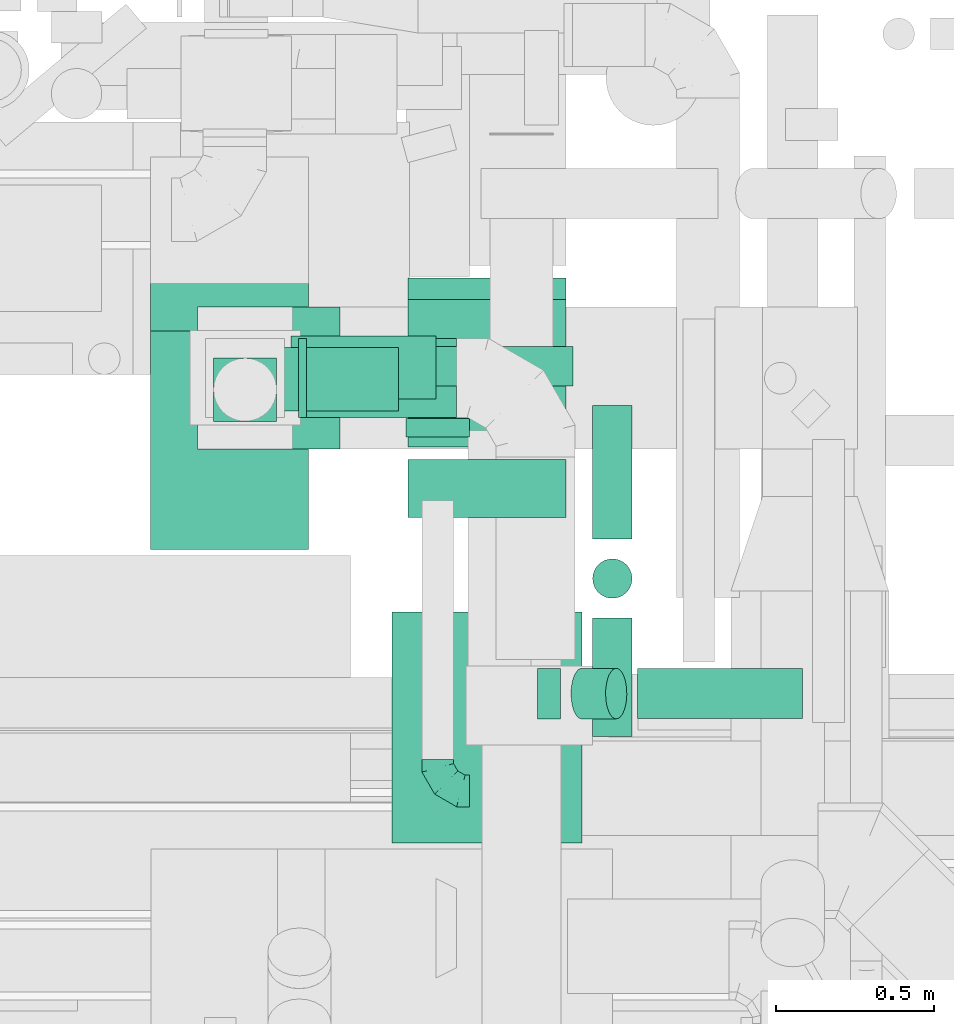
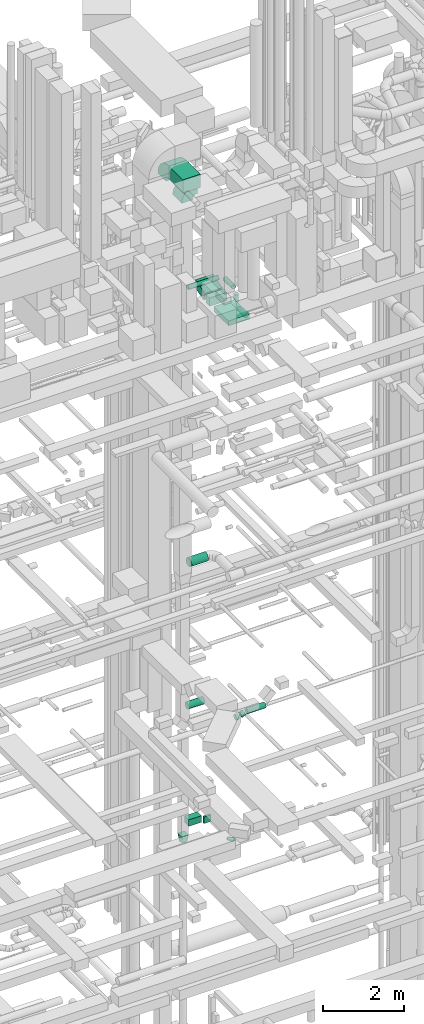
# One storey, part 187 of 337: 15 flow segments, 5 flow fittings.
"""IFC2X3 building model written with IfcOpenShell, lengths in millimetres."""

from ifc_helpers import new_model, entity, si_unit, converted_unit, derived_unit, direction, frame, frame_2d, origin, origin_2d_with_axis, place, context, subcontext, project, spatial, polyline, circle_curve, parameter, trimmed, segment, composite_curve, rectangle, circle, outline, extrude, faceted_brep, source, transform, mapped, material, type_object, type_shapes, element, save


model = new_model("IFC2X3")

# Units and contexts
model_context = context("Model", 3, precision=0.01, world=origin(), true_north=direction((6.12303176911189e-17, 1.0)))
body_context = subcontext(model_context, "Body", "Model", "MODEL_VIEW")
ifc_project = project(units=[si_unit("LENGTHUNIT", "METRE", prefix="MILLI"), si_unit("AREAUNIT", "SQUARE_METRE"), si_unit("VOLUMEUNIT", "CUBIC_METRE"), converted_unit("PLANEANGLEUNIT", "DEGREE", entity("IfcRatioMeasure", 0.0174532925199433), si_unit("PLANEANGLEUNIT", "RADIAN"), dimensions=[0, 0, 0, 0, 0, 0, 0]), si_unit("MASSUNIT", "GRAM", prefix="KILO"), derived_unit("MASSDENSITYUNIT", [(si_unit("MASSUNIT", "GRAM", prefix="KILO"), 1), (si_unit("LENGTHUNIT", "METRE"), -3)]), derived_unit("MOMENTOFINERTIAUNIT", [(si_unit("LENGTHUNIT", "METRE"), 4)]), si_unit("TIMEUNIT", "SECOND"), si_unit("FREQUENCYUNIT", "HERTZ"), si_unit("THERMODYNAMICTEMPERATUREUNIT", "DEGREE_CELSIUS"), derived_unit("THERMALTRANSMITTANCEUNIT", [(si_unit("MASSUNIT", "GRAM", prefix="KILO"), 1), (si_unit("THERMODYNAMICTEMPERATUREUNIT", "KELVIN"), -1), (si_unit("TIMEUNIT", "SECOND"), -3)]), derived_unit("VOLUMETRICFLOWRATEUNIT", [(si_unit("LENGTHUNIT", "METRE"), 3), (si_unit("TIMEUNIT", "SECOND"), -1)]), derived_unit("MASSFLOWRATEUNIT", [(si_unit("MASSUNIT", "GRAM", prefix="KILO"), 1), (si_unit("TIMEUNIT", "SECOND"), -1)]), derived_unit("ROTATIONALFREQUENCYUNIT", [(si_unit("TIMEUNIT", "SECOND"), -1)]), si_unit("ELECTRICCURRENTUNIT", "AMPERE"), si_unit("ELECTRICVOLTAGEUNIT", "VOLT"), si_unit("POWERUNIT", "WATT"), si_unit("FORCEUNIT", "NEWTON", prefix="KILO"), si_unit("ILLUMINANCEUNIT", "LUX"), si_unit("LUMINOUSFLUXUNIT", "LUMEN"), si_unit("LUMINOUSINTENSITYUNIT", "CANDELA"), derived_unit("USERDEFINED", [(si_unit("MASSUNIT", "GRAM", prefix="KILO"), -1), (si_unit("LENGTHUNIT", "METRE"), -2), (si_unit("TIMEUNIT", "SECOND"), 3), (si_unit("LUMINOUSFLUXUNIT", "LUMEN"), 1)]), derived_unit("LINEARVELOCITYUNIT", [(si_unit("LENGTHUNIT", "METRE"), 1), (si_unit("TIMEUNIT", "SECOND"), -1)]), si_unit("PRESSUREUNIT", "PASCAL"), derived_unit("USERDEFINED", [(si_unit("LENGTHUNIT", "METRE"), -2), (si_unit("MASSUNIT", "GRAM", prefix="KILO"), 1), (si_unit("TIMEUNIT", "SECOND"), -2)]), derived_unit("LINEARFORCEUNIT", [(si_unit("MASSUNIT", "GRAM", prefix="KILO"), 1), (si_unit("LENGTHUNIT", "METRE"), 1), (si_unit("TIMEUNIT", "SECOND"), -2), (si_unit("LENGTHUNIT", "METRE"), -1)]), derived_unit("PLANARFORCEUNIT", [(si_unit("MASSUNIT", "GRAM", prefix="KILO"), 1), (si_unit("LENGTHUNIT", "METRE"), 1), (si_unit("TIMEUNIT", "SECOND"), -2), (si_unit("LENGTHUNIT", "METRE"), -2)])], contexts=[model_context])

# Site, building, storey
site_placement = place(None, origin())
site = spatial("IfcSite", under=ifc_project, at=site_placement, CompositionType="ELEMENT")
building_placement = place(site_placement, origin())
building = spatial("IfcBuilding", under=site, at=building_placement, CompositionType="ELEMENT")
storey_placement = place(building_placement, origin())
storey = spatial("IfcBuildingStorey", under=building, at=storey_placement, CompositionType="ELEMENT", Elevation=0.0)

# Flow segments
duct_segment_type_1 = type_object("IfcDuctSegmentType", PredefinedType="NOTDEFINED")
flow_segment_1_placement = place(storey_placement, frame((52720.03, 11170.4, 11370.0)))
element("IfcFlowSegment", 1, at=flow_segment_1_placement, inside=storey, type_object=duct_segment_type_1, context=body_context, shape_type="SweptSolid", body=[
    extrude(rectangle(XDim=364.85556818635, YDim=200.0, at=origin_2d_with_axis()), frame((182.43, 100.0, 0.0), z_axis=(0.0, 0.0, 1.0), x_axis=(-1.0, 0.0, 0.0)), (0.0, 0.0, 1.0), 199.999999999998),
])
flow_segment_2_placement = place(storey_placement, frame((53109.89, 11086.79, 11370.0)))
element("IfcFlowSegment", 2, at=flow_segment_2_placement, inside=storey, type_object=duct_segment_type_1, context=body_context, shape_type="SweptSolid", body=[
    extrude(rectangle(XDim=58.6039573661216, YDim=199.999999999998, at=origin_2d_with_axis()), frame((100.0, 29.3, 0.0), z_axis=(0.0, 0.0, 1.0), x_axis=(0.0, -1.0, 0.0)), (0.0, 0.0, 1.0), 199.999999999998),
])
flow_segment_3_placement = place(storey_placement, frame((53065.82, 9802.55, 27150.0)))
element("IfcFlowSegment", 3, at=flow_segment_3_placement, inside=storey, type_object=duct_segment_type_1, context=body_context, shape_type="SweptSolid", body=[
    extrude(rectangle(XDim=730.779196872407, YDim=600.000000000002, at=origin_2d_with_axis()), frame((300.0, 365.39, 0.0), z_axis=(0.0, 0.0, 1.0), x_axis=(0.0, 1.0, 0.0)), (0.0, 0.0, 1.0), 150.000000000001),
])
flow_segment_4_placement = place(storey_placement, frame((53115.82, 10833.33, 27100.0)))
element("IfcFlowSegment", 4, at=flow_segment_4_placement, inside=storey, type_object=duct_segment_type_1, context=body_context, shape_type="SweptSolid", body=[
    extrude(rectangle(XDim=182.495508005278, YDim=499.999999999999, at=origin_2d_with_axis()), frame((250.0, 91.25, 0.0), z_axis=(0.0, 0.0, 1.0), x_axis=(0.0, 1.0, 0.0)), (0.0, 0.0, 1.0), 250.000000000004),
])
flow_segment_5_placement = place(storey_placement, frame((53115.82, 11056.0, 27114.61)))
element("IfcFlowSegment", 5, at=flow_segment_5_placement, inside=storey, type_object=duct_segment_type_1, context=body_context, shape_type="SweptSolid", body=[
    extrude(rectangle(XDim=250.000000000005, YDim=485.15363912892, at=frame_2d((0.0, 0.0), x_axis=(0.0, 1.0))), frame((0.0, 267.19, 185.39), z_axis=(1.0, 0.0, 0.0), x_axis=(0.0, 0.963480255930641, 0.267779380146841)), (0.0, 0.0, 1.0), 500.000000000008),
])
flow_segment_6_placement = place(storey_placement, frame((52300.35, 10731.5, 30855.02)))
element("IfcFlowSegment", 6, at=flow_segment_6_placement, inside=storey, type_object=duct_segment_type_1, context=body_context, shape_type="SweptSolid", body=[
    extrude(rectangle(XDim=691.839018428497, YDim=499.999999999999, at=origin_2d_with_axis()), frame((250.0, 345.92, 0.0), z_axis=(0.0, 0.0, 1.0), x_axis=(0.0, -1.0, 0.0)), (0.0, 0.0, 1.0), 400.000000000004),
])
duct_segment_type_2 = type_object("IfcDuctSegmentType", PredefinedType="NOTDEFINED")
flow_segment_7_placement = place(storey_placement, frame((52795.03, 11148.01, 19123.4)))
element("IfcFlowSegment", 7, at=flow_segment_7_placement, inside=storey, type_object=duct_segment_type_2, context=body_context, shape_type="SweptSolid", body=[
    extrude(circle(Radius=125.0, at=origin_2d_with_axis()), frame((0.0, 126.6, 126.6), z_axis=(1.0, 0.0, 0.0), x_axis=(0.0, 1.0, 0.0)), (0.0, 0.0, 1.0), 474.855752884465),
])
flow_segment_8_placement = place(storey_placement, frame((52745.03, 11206.18, 14818.4)))
element("IfcFlowSegment", 8, at=flow_segment_8_placement, inside=storey, type_object=duct_segment_type_2, context=body_context, shape_type="SweptSolid", body=[
    extrude(circle(Radius=100.0, at=origin_2d_with_axis()), frame((0.0, 101.6, 101.6), z_axis=(1.0, 0.0, 0.0), x_axis=(0.0, -1.0, 0.0)), (0.0, 0.0, 1.0), 459.993030000456),
])
flow_segment_9_placement = place(storey_placement, frame((53841.96, 10193.45, 14918.4)))
element("IfcFlowSegment", 9, at=flow_segment_9_placement, inside=storey, type_object=duct_segment_type_2, context=body_context, shape_type="SweptSolid", body=[
    extrude(circle(Radius=80.0, at=origin_2d_with_axis()), frame((0.0, 81.6, 81.6), z_axis=(1.0, 0.0, 0.0), x_axis=(0.0, 1.0, 0.0)), (0.0, 0.0, 1.0), 523.066679994511),
])
flow_segment_10_placement = place(storey_placement, frame((53525.03, 10193.45, 14838.4)))
element("IfcFlowSegment", 10, at=flow_segment_10_placement, inside=storey, type_object=duct_segment_type_2, context=body_context, shape_type="SweptSolid", body=[
    extrude(circle(Radius=80.0, at=origin_2d_with_axis()), frame((0.0, 81.6, 81.6), z_axis=(1.0, 0.0, 0.0), x_axis=(0.0, -1.0, 0.0)), (0.0, 0.0, 1.0), 73.3971976432189),
])
flow_segment_11_placement = place(storey_placement, frame((53630.37, 10193.45, 14860.52)))
element("IfcFlowSegment", 11, at=flow_segment_11_placement, inside=storey, type_object=duct_segment_type_2, context=body_context, shape_type="SweptSolid", body=[
    extrude(circle(Radius=80.0, at=origin_2d_with_axis()), frame((35.14, 81.6, 74.22), z_axis=(0.907841304111058, 0.0, 0.419313923629937), x_axis=(0.0, -1.0, 0.0)), (0.0, 0.0, 1.0), 120.456809252341),
])
flow_segment_12_placement = place(storey_placement, frame((52770.03, 11248.01, 27435.9)))
element("IfcFlowSegment", 12, at=flow_segment_12_placement, inside=storey, type_object=duct_segment_type_2, context=body_context, shape_type="SweptSolid", body=[
    extrude(circle(Radius=62.5, at=origin_2d_with_axis()), frame((0.0, 64.1, 64.1), z_axis=(1.0, 0.0, 0.0), x_axis=(0.0, 1.0, 0.0)), (0.0, 0.0, 1.0), 867.694165656165),
])
flow_segment_13_placement = place(storey_placement, frame((53698.63, 10139.17, 26945.9)))
element("IfcFlowSegment", 13, at=flow_segment_13_placement, inside=storey, type_object=duct_segment_type_2, context=body_context, shape_type="SweptSolid", body=[
    extrude(circle(Radius=62.5, at=origin_2d_with_axis()), frame((64.1, 0.0, 64.1), z_axis=(0.0, 1.0, 0.0), x_axis=(1.0, 0.0, 0.0)), (0.0, 0.0, 1.0), 374.999999999984),
])
flow_segment_14_placement = place(storey_placement, frame((53698.63, 10764.17, 27435.9)))
element("IfcFlowSegment", 14, at=flow_segment_14_placement, inside=storey, type_object=duct_segment_type_2, context=body_context, shape_type="SweptSolid", body=[
    extrude(circle(Radius=62.5, at=origin_2d_with_axis()), frame((64.1, 0.0, 64.1), z_axis=(0.0, 1.0, 0.0), x_axis=(-1.0, 0.0, 0.0)), (0.0, 0.0, 1.0), 422.937639147138),
])
flow_segment_15_placement = place(storey_placement, frame((53698.63, 10575.07, 27135.0)))
element("IfcFlowSegment", 15, at=flow_segment_15_placement, inside=storey, type_object=duct_segment_type_2, context=body_context, shape_type="SweptSolid", body=[
    extrude(circle(Radius=62.5, at=origin_2d_with_axis()), frame((64.1, 64.1, 0.0), z_axis=(0.0, 0.0, 1.0), x_axis=(-1.0, 0.0, 0.0)), (0.0, 0.0, 1.0), 240.000000000002),
])

# Flow fittings
ifc_material = material()
duct_fitting_type_1 = type_object("IfcDuctFittingType", PredefinedType="NOTDEFINED", material=ifc_material)
shared_shape_1 = source(origin(), body_context, "Body", "Brep", [
    faceted_brep([(-100.0, 0.0, -50.0), (-100.0, -12.94, -48.3), (-100.0, -25.0, -43.3), (-100.0, -35.36, -35.36), (-100.0, -43.3, -25.0), (-100.0, -48.3, -12.94), (-100.0, -50.0, 0.0), (-100.0, -48.3, 12.94), (-100.0, -43.3, 25.0), (-100.0, -35.36, 35.36), (-100.0, -25.0, 43.3), (-100.0, -12.94, 48.3), (-100.0, 0.0, 50.0), (-100.0, 12.94, 48.3), (-100.0, 25.0, 43.3), (-100.0, 35.36, 35.36), (-100.0, 43.3, 25.0), (-100.0, 48.3, 12.94), (-100.0, 50.0, 0.0), (-100.0, 48.3, -12.94), (-100.0, 43.3, -25.0), (-100.0, 35.36, -35.36), (-100.0, 25.0, -43.3), (-100.0, 12.94, -48.3), (-76.67, 12.94, 48.3), (-79.9, 25.0, 43.3), (-73.21, 0.0, 50.0), (-82.68, 35.36, 35.36), (-86.15, 48.3, 12.94), (-86.6, 50.0, 0.0), (-84.81, 43.3, 25.0), (-84.81, 43.3, -25.0), (-82.68, 35.36, -35.36), (-86.15, 48.3, -12.94), (-76.67, 12.94, -48.3), (-73.21, 0.0, -50.0), (-79.9, 25.0, -43.3), (-69.74, -12.94, -48.3), (-66.51, -25.0, -43.3), (-63.73, -35.36, -35.36), (-61.6, -43.3, -25.0), (-60.26, -48.3, -12.94), (-59.81, -50.0, 0.0), (-60.26, -48.3, 12.94), (-61.6, -43.3, 25.0), (-63.73, -35.36, 35.36), (-66.51, -25.0, 43.3), (-69.74, -12.94, 48.3), (-36.27, 36.27, 48.3), (-45.1, 45.1, 43.3), (-26.79, 26.79, 50.0), (-52.68, 52.68, 35.36), (-58.49, 58.49, 25.0), (-62.15, 62.15, 12.94), (-63.4, 63.4, 0.0), (-62.15, 62.15, -12.94), (-58.49, 58.49, -25.0), (-52.68, 52.68, -35.36), (-36.27, 36.27, -48.3), (-26.79, 26.79, -50.0), (-45.1, 45.1, -43.3), (-17.32, 17.32, -48.3), (-8.49, 8.49, -43.3), (-0.91, 0.91, -35.36), (4.9, -4.9, -25.0), (8.56, -8.56, -12.94), (9.81, -9.81, 0.0), (8.56, -8.56, 12.94), (4.9, -4.9, 25.0), (-0.91, 0.91, 35.36), (-8.49, 8.49, 43.3), (-17.32, 17.32, 48.3), (-12.94, 76.67, 48.3), (-25.0, 79.9, 43.3), (0.0, 73.21, 50.0), (-35.36, 82.68, 35.36), (-43.3, 84.81, 25.0), (-48.3, 86.15, 12.94), (-50.0, 86.6, 0.0), (-48.3, 86.15, -12.94), (-43.3, 84.81, -25.0), (-35.36, 82.68, -35.36), (-12.94, 76.67, -48.3), (0.0, 73.21, -50.0), (-25.0, 79.9, -43.3), (12.94, 69.74, -48.3), (25.0, 66.51, -43.3), (35.36, 63.73, -35.36), (43.3, 61.6, -25.0), (48.3, 60.26, -12.94), (50.0, 59.81, 0.0), (48.3, 60.26, 12.94), (43.3, 61.6, 25.0), (35.36, 63.73, 35.36), (25.0, 66.51, 43.3), (12.94, 69.74, 48.3), (-12.94, 100.0, -48.3), (-25.0, 100.0, -43.3), (-35.36, 100.0, -35.36), (-43.3, 100.0, -25.0), (-48.3, 100.0, -12.94), (-50.0, 100.0, 0.0), (-48.3, 100.0, 12.94), (-43.3, 100.0, 25.0), (-35.36, 100.0, 35.36), (-25.0, 100.0, 43.3), (-12.94, 100.0, 48.3), (0.0, 100.0, 50.0), (12.94, 100.0, 48.3), (25.0, 100.0, 43.3), (35.36, 100.0, 35.36), (43.3, 100.0, 25.0), (48.3, 100.0, 12.94), (50.0, 100.0, 0.0), (48.3, 100.0, -12.94), (43.3, 100.0, -25.0), (35.36, 100.0, -35.36), (25.0, 100.0, -43.3), (12.94, 100.0, -48.3), (0.0, 100.0, -50.0)], [[[0, 1, 2, 3, 4, 5, 6, 7, 8, 9, 10, 11, 12, 13, 14, 15, 16, 17, 18, 19, 20, 21, 22, 23]], [[24, 25, 14, 13]], [[26, 24, 13, 12]], [[14, 25, 27, 15]], [[28, 29, 18, 17]], [[30, 28, 17, 16]], [[15, 27, 30, 16]], [[20, 31, 32, 21]], [[33, 31, 20, 19]], [[18, 29, 33, 19]], [[34, 35, 0, 23]], [[36, 34, 23, 22]], [[32, 36, 22, 21]], [[2, 1, 37, 38]], [[3, 2, 38, 39]], [[0, 35, 37, 1]], [[5, 4, 40, 41]], [[6, 5, 41, 42]], [[3, 39, 40, 4]], [[6, 42, 43, 7]], [[7, 43, 44, 8]], [[8, 44, 45, 9]], [[10, 46, 47, 11]], [[11, 47, 26, 12]], [[10, 9, 45, 46]], [[48, 49, 25, 24]], [[50, 48, 24, 26]], [[27, 25, 49, 51]], [[52, 53, 28, 30]], [[51, 52, 30, 27]], [[29, 28, 53, 54]], [[55, 56, 31, 33]], [[54, 55, 33, 29]], [[57, 32, 31, 56]], [[58, 59, 35, 34]], [[60, 58, 34, 36]], [[57, 60, 36, 32]], [[37, 35, 59, 61]], [[38, 37, 61, 62]], [[39, 38, 62, 63]], [[41, 40, 64, 65]], [[42, 41, 65, 66]], [[63, 64, 40, 39]], [[43, 42, 66, 67]], [[44, 43, 67, 68]], [[68, 69, 45, 44]], [[46, 45, 69, 70]], [[47, 46, 70, 71]], [[26, 47, 71, 50]], [[72, 73, 49, 48]], [[74, 72, 48, 50]], [[51, 49, 73, 75]], [[76, 77, 53, 52]], [[75, 76, 52, 51]], [[54, 53, 77, 78]], [[79, 80, 56, 55]], [[78, 79, 55, 54]], [[81, 57, 56, 80]], [[82, 83, 59, 58]], [[84, 82, 58, 60]], [[81, 84, 60, 57]], [[61, 59, 83, 85]], [[62, 61, 85, 86]], [[63, 62, 86, 87]], [[65, 64, 88, 89]], [[66, 65, 89, 90]], [[87, 88, 64, 63]], [[67, 66, 90, 91]], [[68, 67, 91, 92]], [[92, 93, 69, 68]], [[70, 69, 93, 94]], [[71, 70, 94, 95]], [[50, 71, 95, 74]], [[96, 97, 98, 99, 100, 101, 102, 103, 104, 105, 106, 107, 108, 109, 110, 111, 112, 113, 114, 115, 116, 117, 118, 119]], [[72, 74, 107, 106]], [[73, 72, 106, 105]], [[75, 73, 105, 104]], [[77, 76, 103, 102]], [[78, 77, 102, 101]], [[75, 104, 103, 76]], [[78, 101, 100, 79]], [[79, 100, 99, 80]], [[80, 99, 98, 81]], [[96, 119, 83, 82]], [[97, 96, 82, 84]], [[84, 81, 98, 97]], [[83, 119, 118, 85]], [[85, 118, 117, 86]], [[86, 117, 116, 87]], [[88, 115, 114, 89]], [[89, 114, 113, 90]], [[87, 116, 115, 88]], [[91, 90, 113, 112]], [[92, 91, 112, 111]], [[93, 92, 111, 110]], [[95, 94, 109, 108]], [[74, 95, 108, 107]], [[110, 109, 94, 93]]]),
])
type_shapes(duct_fitting_type_1, [shared_shape_1])
flow_fitting_1_placement = place(storey_placement, frame((53209.89, 9966.79, 11520.0), z_axis=(0.0, 0.0, 1.0), x_axis=(0.0, -1.0, 0.0)))
element("IfcFlowFitting", 16, at=flow_fitting_1_placement, inside=storey, type_object=duct_fitting_type_1, material=ifc_material, context=body_context, shape_type="MappedRepresentation", body=[
    mapped(shared_shape_1, transform((0.0, 0.0, 0.0), scale=1.0)),
])
duct_fitting_type_2 = type_object("IfcDuctFittingType", PredefinedType="NOTDEFINED", material=ifc_material)
shared_shape_2 = source(origin(), body_context, "Body", "Brep", [
    faceted_brep([(20.0, 32.35, -120.74), (20.0, 62.5, -108.25), (20.0, 88.39, -88.39), (20.0, 108.25, -62.5), (20.0, 120.74, -32.35), (20.0, 125.0, 0.0), (20.0, 120.74, 32.35), (20.0, 108.25, 62.5), (20.0, 88.39, 88.39), (20.0, 62.5, 108.25), (20.0, 32.35, 120.74), (20.0, 0.0, 125.0), (20.0, -32.35, 120.74), (20.0, -62.5, 108.25), (20.0, -88.39, 88.39), (20.0, -108.25, 62.5), (20.0, -120.74, 32.35), (20.0, -125.0, 0.0), (20.0, -120.74, -32.35), (20.0, -108.25, -62.5), (20.0, -88.39, -88.39), (20.0, -62.5, -108.25), (20.0, -32.35, -120.74), (20.0, 0.0, -125.0), (0.0, 0.0, 125.0), (0.0, 32.35, 120.74), (-6.1, 32.35, 120.74), (-6.1, 0.0, 125.0), (0.0, 62.5, 108.25), (-6.1, 62.5, 108.25), (0.0, 88.39, 88.39), (-6.1, 88.39, 88.39), (0.0, 108.25, 62.5), (0.0, 120.74, 32.35), (-6.1, 120.74, 32.35), (-6.1, 108.25, 62.5), (0.0, 125.0, 0.0), (-6.1, 125.0, 0.0), (0.0, 120.74, -32.35), (-6.1, 120.74, -32.35), (0.0, 108.25, -62.5), (-6.1, 108.25, -62.5), (0.0, 88.39, -88.39), (-6.1, 88.39, -88.39), (0.0, 62.5, -108.25), (0.0, 32.35, -120.74), (-6.1, 32.35, -120.74), (-6.1, 62.5, -108.25), (0.0, 0.0, -125.0), (-6.1, 0.0, -125.0), (0.0, -32.35, -120.74), (-6.1, -32.35, -120.74), (0.0, -62.5, -108.25), (-6.1, -62.5, -108.25), (0.0, -88.39, -88.39), (-6.1, -88.39, -88.39), (0.0, -108.25, -62.5), (0.0, -120.74, -32.35), (-6.1, -120.74, -32.35), (-6.1, -108.25, -62.5), (0.0, -125.0, 0.0), (-6.1, -125.0, 0.0), (0.0, -120.74, 32.35), (-6.1, -120.74, 32.35), (0.0, -108.25, 62.5), (-6.1, -108.25, 62.5), (0.0, -88.39, 88.39), (-6.1, -88.39, 88.39), (0.0, -62.5, 108.25), (0.0, -32.35, 120.74), (-6.1, -32.35, 120.74), (-6.1, -62.5, 108.25)], [[[0, 1, 2, 3, 4, 5, 6, 7, 8, 9, 10, 11, 12, 13, 14, 15, 16, 17, 18, 19, 20, 21, 22, 23]], [[24, 11, 10, 25, 26, 27]], [[25, 10, 9, 28, 29, 26]], [[28, 9, 8, 30, 31, 29]], [[32, 7, 6, 33, 34, 35]], [[33, 6, 5, 36, 37, 34]], [[30, 8, 7, 32, 35, 31]], [[36, 5, 4, 38, 39, 37]], [[38, 4, 3, 40, 41, 39]], [[40, 3, 2, 42, 43, 41]], [[44, 1, 0, 45, 46, 47]], [[45, 0, 23, 48, 49, 46]], [[42, 2, 1, 44, 47, 43]], [[48, 23, 22, 50, 51, 49]], [[50, 22, 21, 52, 53, 51]], [[52, 21, 20, 54, 55, 53]], [[56, 19, 18, 57, 58, 59]], [[57, 18, 17, 60, 61, 58]], [[54, 20, 19, 56, 59, 55]], [[60, 17, 16, 62, 63, 61]], [[62, 16, 15, 64, 65, 63]], [[64, 15, 14, 66, 67, 65]], [[68, 13, 12, 69, 70, 71]], [[69, 12, 11, 24, 27, 70]], [[66, 14, 13, 68, 71, 67]], [[49, 51, 53, 55, 59, 58, 61, 63, 65, 67, 71, 70, 27, 26, 29, 31, 35, 34, 37, 39, 41, 43, 47, 46]]]),
])
type_shapes(duct_fitting_type_2, [shared_shape_2])
flow_fitting_2_placement = place(storey_placement, frame((52775.03, 11274.6, 19250.0), z_axis=(0.0, -1.0, 0.0), x_axis=(1.0, 0.0, 0.0)))
element("IfcFlowFitting", 17, at=flow_fitting_2_placement, inside=storey, type_object=duct_fitting_type_2, material=ifc_material, context=body_context, shape_type="MappedRepresentation", body=[
    mapped(shared_shape_2, transform((0.0, 0.0, 0.0), scale=1.0)),
])
duct_fitting_type_3 = type_object("IfcDuctFittingType", PredefinedType="NOTDEFINED", material=ifc_material)
shared_shape_3 = source(origin(), body_context, "Body", "Brep", [
    faceted_brep([(200.0, 30.9, 95.11), (200.0, 19.08, 96.98), (200.0, 9.54, 98.49), (200.0, 4.77, 99.24), (200.0, 0.0, 100.0), (200.0, -4.77, 99.24), (200.0, -9.54, 98.49), (200.0, -19.08, 96.98), (200.0, -30.9, 95.11), (200.0, -44.84, 88.0), (200.0, -58.78, 80.9), (200.0, -69.84, 69.84), (200.0, -80.9, 58.78), (200.0, -88.0, 44.84), (200.0, -95.11, 30.9), (200.0, -96.98, 19.08), (200.0, -98.49, 9.54), (200.0, -99.24, 4.77), (200.0, -100.0, 0.0), (200.0, -99.24, -4.77), (200.0, -98.49, -9.54), (200.0, -96.98, -19.08), (200.0, -95.11, -30.9), (200.0, -88.0, -44.84), (200.0, -80.9, -58.78), (200.0, -69.84, -69.84), (200.0, -58.78, -80.9), (200.0, -44.84, -88.0), (200.0, -30.9, -95.11), (200.0, -19.08, -96.98), (200.0, -9.54, -98.49), (200.0, -4.77, -99.24), (200.0, 0.0, -100.0), (200.0, 4.77, -99.24), (200.0, 9.54, -98.49), (200.0, 19.08, -96.98), (200.0, 30.9, -95.11), (200.0, 44.84, -88.0), (200.0, 58.78, -80.9), (200.0, 69.84, -69.84), (200.0, 80.9, -58.78), (200.0, 88.0, -44.84), (200.0, 95.11, -30.9), (200.0, 96.98, -19.08), (200.0, 98.49, -9.54), (200.0, 99.24, -4.77), (200.0, 100.0, 0.0), (200.0, 99.24, 4.77), (200.0, 98.49, 9.54), (200.0, 96.98, 19.08), (200.0, 95.11, 30.9), (200.0, 88.0, 44.84), (200.0, 80.9, 58.78), (200.0, 69.84, 69.84), (200.0, 58.78, 80.9), (200.0, 44.84, 88.0), (0.0, -100.0, 100.0), (0.0, 100.0, 100.0), (0.0, 100.0, -100.0), (0.0, -100.0, -100.0), (104.11, -47.94, 100.0), (100.0, -83.15, 87.43), (26.03, -86.99, 100.0), (78.09, -60.96, 100.0), (52.06, -73.97, 100.0), (188.01, -5.99, 100.0), (176.03, -11.99, 100.0), (152.06, -23.97, 100.0), (128.09, -35.96, 100.0), (52.06, -100.0, 73.97), (78.09, -100.0, 60.96), (104.11, -100.0, 47.94), (128.09, -100.0, 35.96), (152.06, -100.0, 23.97), (176.03, -100.0, 11.99), (188.01, -100.0, 5.99), (26.03, -100.0, 86.99), (26.03, -100.0, -86.99), (52.06, -100.0, -73.97), (78.09, -100.0, -60.96), (104.11, -100.0, -47.94), (128.09, -100.0, -35.96), (152.06, -100.0, -23.97), (176.03, -100.0, -11.99), (188.01, -100.0, -5.99), (100.0, -87.43, -83.15), (52.06, -73.97, -100.0), (78.09, -60.96, -100.0), (104.11, -47.94, -100.0), (128.09, -35.96, -100.0), (152.06, -23.97, -100.0), (176.03, -11.99, -100.0), (188.01, -5.99, -100.0), (26.03, -86.99, -100.0), (26.03, 86.99, -100.0), (52.06, 73.97, -100.0), (78.09, 60.96, -100.0), (104.11, 47.94, -100.0), (128.09, 35.96, -100.0), (152.06, 23.97, -100.0), (176.03, 11.99, -100.0), (188.01, 5.99, -100.0), (100.0, 83.15, -87.43), (52.06, 100.0, -73.97), (78.09, 100.0, -60.96), (104.11, 100.0, -47.94), (128.09, 100.0, -35.96), (152.06, 100.0, -23.97), (176.03, 100.0, -11.99), (188.01, 100.0, -5.99), (26.03, 100.0, -86.99), (26.03, 100.0, 86.99), (52.06, 100.0, 73.97), (78.09, 100.0, 60.96), (104.11, 100.0, 47.94), (128.09, 100.0, 35.96), (152.06, 100.0, 23.97), (176.03, 100.0, 11.99), (188.01, 100.0, 5.99), (100.0, 87.43, 83.15), (52.06, 73.97, 100.0), (78.09, 60.96, 100.0), (104.11, 47.94, 100.0), (128.09, 35.96, 100.0), (152.06, 23.97, 100.0), (176.03, 11.99, 100.0), (188.01, 5.99, 100.0), (26.03, 86.99, 100.0)], [[[0, 1, 2, 3, 4, 5, 6, 7, 8, 9, 10, 11, 12, 13, 14, 15, 16, 17, 18, 19, 20, 21, 22, 23, 24, 25, 26, 27, 28, 29, 30, 31, 32, 33, 34, 35, 36, 37, 38, 39, 40, 41, 42, 43, 44, 45, 46, 47, 48, 49, 50, 51, 52, 53, 54, 55]], [[56, 57, 58, 59]], [[60, 9, 8]], [[56, 61, 62]], [[9, 60, 63, 64]], [[65, 66, 67, 68, 60, 8, 7, 6, 5, 4]], [[62, 61, 10]], [[13, 69, 70, 71]], [[64, 10, 9]], [[14, 71, 72, 73, 74, 75, 18, 17, 16, 15]], [[12, 76, 69]], [[71, 14, 13]], [[61, 76, 11]], [[10, 64, 62]], [[76, 12, 11]], [[10, 61, 11]], [[61, 56, 76]], [[69, 13, 12]], [[75, 74, 73, 72, 71, 70, 69, 76, 56, 59, 77, 78, 79, 80, 81, 82, 83, 84, 18]], [[80, 23, 22]], [[59, 85, 77]], [[23, 80, 79, 78]], [[84, 83, 82, 81, 80, 22, 21, 20, 19, 18]], [[77, 85, 24]], [[27, 86, 87, 88]], [[78, 24, 23]], [[28, 88, 89, 90, 91, 92, 32, 31, 30, 29]], [[26, 93, 86]], [[88, 28, 27]], [[85, 93, 25]], [[24, 78, 77]], [[93, 26, 25]], [[24, 85, 25]], [[85, 59, 93]], [[86, 27, 26]], [[92, 91, 90, 89, 88, 87, 86, 93, 59, 58, 94, 95, 96, 97, 98, 99, 100, 101, 32]], [[97, 37, 36]], [[58, 102, 94]], [[37, 97, 96, 95]], [[101, 100, 99, 98, 97, 36, 35, 34, 33, 32]], [[94, 102, 38]], [[41, 103, 104, 105]], [[95, 38, 37]], [[42, 105, 106, 107, 108, 109, 46, 45, 44, 43]], [[40, 110, 103]], [[105, 42, 41]], [[102, 110, 39]], [[38, 95, 94]], [[110, 40, 39]], [[38, 102, 39]], [[102, 58, 110]], [[103, 41, 40]], [[58, 57, 111, 112, 113, 114, 115, 116, 117, 118, 46, 109, 108, 107, 106, 105, 104, 103, 110]], [[114, 51, 50]], [[57, 119, 111]], [[51, 114, 113, 112]], [[118, 117, 116, 115, 114, 50, 49, 48, 47, 46]], [[111, 119, 52]], [[55, 120, 121, 122]], [[112, 52, 51]], [[0, 122, 123, 124, 125, 126, 4, 3, 2, 1]], [[54, 127, 120]], [[122, 0, 55]], [[119, 127, 53]], [[52, 112, 111]], [[127, 54, 53]], [[52, 119, 53]], [[119, 57, 127]], [[120, 55, 54]], [[57, 56, 62, 64, 63, 60, 68, 67, 66, 65, 4, 126, 125, 124, 123, 122, 121, 120, 127]]]),
])
type_shapes(duct_fitting_type_3, [shared_shape_3])
flow_fitting_3_placement = place(storey_placement, frame((52600.03, 11237.23, 11150.0), z_axis=(1.0, 0.0, 0.0), x_axis=(0.0, 0.0, -1.0)))
element("IfcFlowFitting", 18, at=flow_fitting_3_placement, inside=storey, type_object=duct_fitting_type_3, material=ifc_material, context=body_context, shape_type="MappedRepresentation", body=[
    mapped(shared_shape_3, transform((0.0, 0.0, 0.0), scale=1.0)),
])
duct_fitting_type_4 = type_object("IfcDuctFittingType", PredefinedType="NOTDEFINED", material=ifc_material)
shared_shape_4 = source(origin(), body_context, "Body", "SweptSolid", [
    extrude(outline(composite_curve([segment(polyline([(-374.99, -175.0), (25.01, -175.0)]), True, "CONTINUOUS"), segment(trimmed(circle_curve(frame_2d((175.01, -175.0), x_axis=(-3.76594630608906e-05, 1.0)), 150.0), [parameter(0.0)], [parameter(89.9978422717069)], True, "PARAMETER"), False, "CONTINUOUS"), segment(polyline([(175.0, -25.0), (174.99, 375.0)]), True, "CONTINUOUS"), segment(trimmed(circle_curve(frame_2d((175.01, -175.0), x_axis=(-3.76594630608906e-05, 1.0)), 550.0), [parameter(0.0)], [parameter(89.9978422717068)], True, "PARAMETER"), True, "CONTINUOUS")], self_intersect=False)), frame((-174.99, 174.99, -250.0), z_axis=(0.0, 0.0, 1.0), x_axis=(-1.0, 3.76594630713853e-05, 0.0)), (0.0, 0.0, 1.0), 500.0),
])
type_shapes(duct_fitting_type_4, [shared_shape_4])
flow_fitting_4_placement = place(storey_placement, frame((52550.35, 11773.33, 31055.02), z_axis=(1.0, 0.0, 0.0), x_axis=(0.0, -3.76594630703914e-05, 1.0)))
element("IfcFlowFitting", 19, at=flow_fitting_4_placement, inside=storey, type_object=duct_fitting_type_4, material=ifc_material, context=body_context, shape_type="MappedRepresentation", body=[
    mapped(shared_shape_4, transform((0.0, 0.0, 0.0), scale=1.0)),
])
duct_fitting_type_5 = type_object("IfcDuctFittingType", PredefinedType="NOTDEFINED", material=ifc_material)
shared_shape_5 = source(origin(), body_context, "Body", "SweptSolid", [
    extrude(outline(composite_curve([segment(polyline([(-300.0, -150.0), (0.0, -150.0)]), True, "CONTINUOUS"), segment(trimmed(circle_curve(frame_2d((150.0, -150.0), x_axis=(0.0, 1.0)), 150.0), [parameter(0.0)], [parameter(90.0)], True, "PARAMETER"), False, "CONTINUOUS"), segment(polyline([(150.0, 0.0), (150.0, 300.0)]), True, "CONTINUOUS"), segment(trimmed(circle_curve(frame_2d((150.0, -150.0), x_axis=(0.0, 1.0)), 450.0), [parameter(0.0)], [parameter(90.0000000000001)], True, "PARAMETER"), True, "CONTINUOUS")], self_intersect=False)), frame((-150.0, 150.0, -225.0), z_axis=(0.0, 0.0, 1.0), x_axis=(-1.0, 0.0, 0.0)), (0.0, 0.0, 1.0), 450.0),
])
type_shapes(duct_fitting_type_5, [shared_shape_5])
flow_fitting_5_placement = place(storey_placement, frame((52600.03, 11274.6, 30600.0), z_axis=(0.0, 1.0, 0.0), x_axis=(0.0, 0.0, 1.0)))
element("IfcFlowFitting", 20, at=flow_fitting_5_placement, inside=storey, type_object=duct_fitting_type_5, material=ifc_material, context=body_context, shape_type="MappedRepresentation", body=[
    mapped(shared_shape_5, transform((0.0, 0.0, 0.0), scale=1.0)),
])

save(model, "model.ifc")
